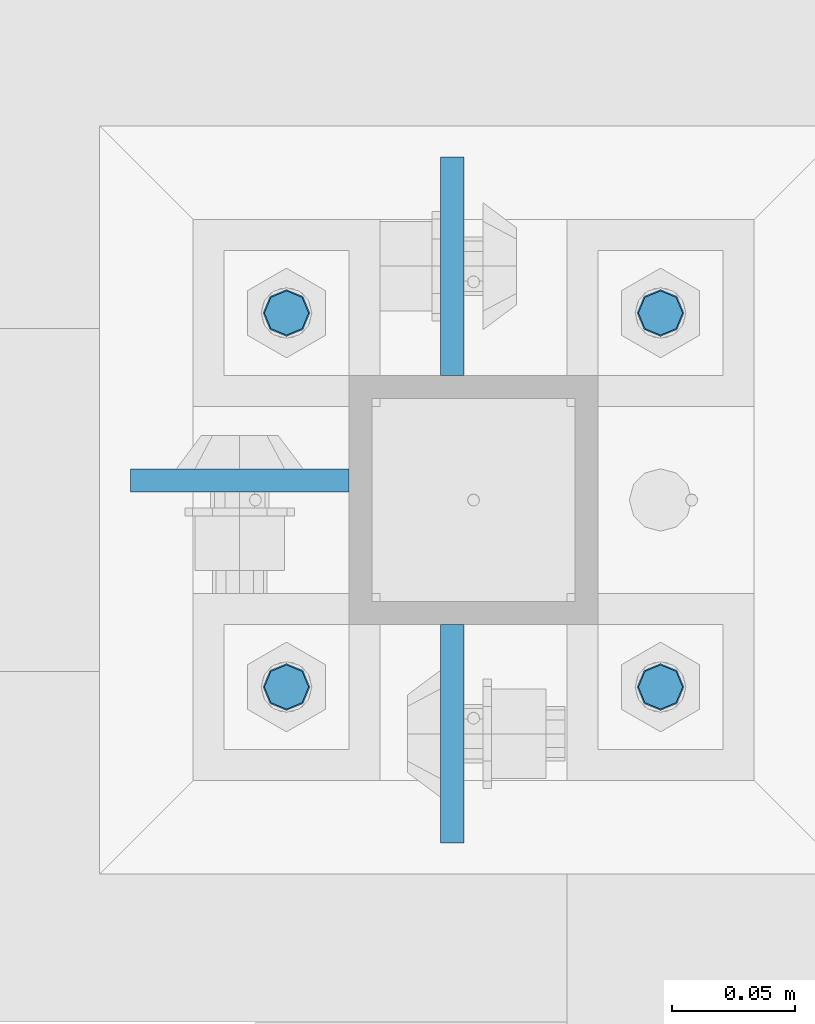
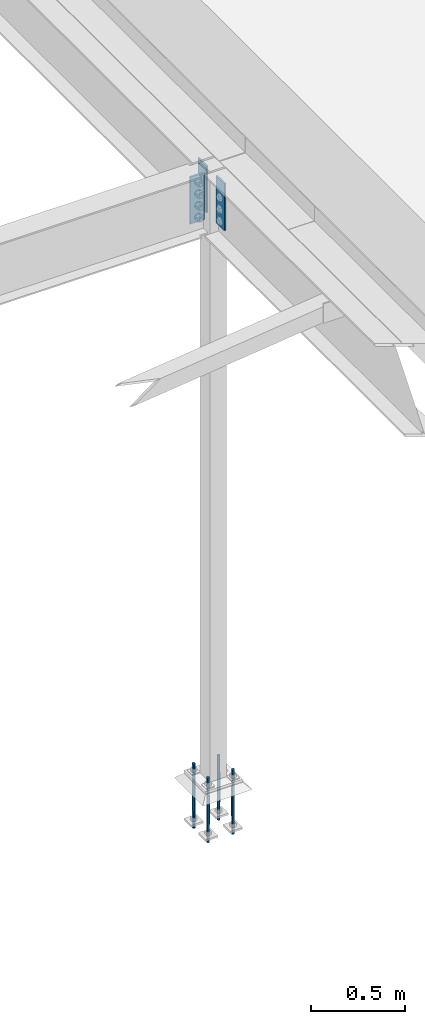
# One storey, part 1550 of 3843: 7 columns, 2 elements without a shape of their own.
"""IFC2X3 building model written with IfcOpenShell, lengths in millimetres."""

import ifcopenshell
import ifcopenshell.guid

model = None  # the IFC model being written
_history = None  # IfcOwnerHistory: only IFC2X3 demands one
_inside = {}  # id of a spatial element -> (the spatial element, [elements in it])
_under = {}  # id of a project, library or spatial element -> (it, [spatial elements below it])
_declared = {}  # id of a project -> (the project, [libraries it declares])
_typed = {}  # id of a type object -> (the type object, [elements of that type])
_made_of = {}  # id of a material, layer set ... -> (it, [elements and type objects made of it])


def new_model(schema):
    """Start an empty IFC model of exactly this schema.

    Asked for "IFC4X3", IfcOpenShell would pick the latest addendum, in which some entities
    have other attributes; the version numbers below select the first issue.
    IFC2X3 requires an IfcOwnerHistory on every rooted entity: one is made here for all.
    """
    global model, _history
    if schema == "IFC4X3":
        model = ifcopenshell.file(schema_version=(4, 3, 0, 0))
    else:
        model = ifcopenshell.file(schema=schema)
    _inside.clear()
    _under.clear()
    _declared.clear()
    _typed.clear()
    _made_of.clear()
    _history = None
    if model.schema == "IFC2X3":
        org = make("IfcOrganization", Name="unknown")
        user = make(
            "IfcPersonAndOrganization",
            ThePerson=make("IfcPerson", FamilyName="unknown"),
            TheOrganization=org,
        )
        app = make(
            "IfcApplication",
            ApplicationDeveloper=org,
            Version="unknown",
            ApplicationFullName="unknown",
            ApplicationIdentifier="unknown",
        )
        _history = make(
            "IfcOwnerHistory",
            OwningUser=user,
            OwningApplication=app,
            ChangeAction="ADDED",
            CreationDate=0,
        )
    return model


def make(cls, **values):
    """One entity of the class cls with the attributes given. An attribute that is None is left unset."""
    return model.create_entity(
        cls, **{name: value for name, value in values.items() if value is not None}
    )


def rooted(cls, **values):
    """An entity with a GlobalId (a new one), such as an element, a storey or a relation."""
    return make(cls, GlobalId=ifcopenshell.guid.new(), OwnerHistory=_history, **values)


def si_unit(unit_type, name, prefix=None):
    """IfcSIUnit, for example si_unit("LENGTHUNIT", "METRE", prefix="MILLI")."""
    return make("IfcSIUnit", UnitType=unit_type, Prefix=prefix, Name=name)


def assignment(units):
    """IfcUnitAssignment: the units of a project."""
    return None if units is None else make("IfcUnitAssignment", Units=units)


def point(xyz):
    """IfcCartesianPoint."""
    return None if xyz is None else make("IfcCartesianPoint", Coordinates=xyz)


def direction(xyz):
    """IfcDirection."""
    return None if xyz is None else make("IfcDirection", DirectionRatios=xyz)


def frame(location, z_axis=None, x_axis=None):
    """IfcAxis2Placement3D, a coordinate frame: its origin and axes. An axis left out is left unset."""
    return make(
        "IfcAxis2Placement3D",
        Location=point(location),
        Axis=direction(z_axis),
        RefDirection=direction(x_axis),
    )


def origin_with_axes():
    """The frame at (0, 0, 0) with the z axis (0, 0, 1) and the x axis (1, 0, 0) written out."""
    return frame((0.0, 0.0, 0.0), z_axis=(0.0, 0.0, 1.0), x_axis=(1.0, 0.0, 0.0))


def place(relative_to, where):
    """IfcLocalPlacement: puts the frame where relative to a parent placement (None: the world)."""
    return make(
        "IfcLocalPlacement", PlacementRelTo=relative_to, RelativePlacement=where
    )


def context(
    kind, dimensions, precision=None, world=None, true_north=None, identifier=None
):
    """IfcGeometricRepresentationContext, for example the 3D "Model" context."""
    return make(
        "IfcGeometricRepresentationContext",
        ContextIdentifier=identifier,
        ContextType=kind,
        CoordinateSpaceDimension=dimensions,
        Precision=precision,
        WorldCoordinateSystem=world,
        TrueNorth=true_north,
    )


def subcontext(parent, identifier, kind, view, scale=None):
    """IfcGeometricRepresentationSubContext, for example "Body" below "Model"."""
    return make(
        "IfcGeometricRepresentationSubContext",
        ContextIdentifier=identifier,
        ContextType=kind,
        ParentContext=parent,
        TargetScale=scale,
        TargetView=view,
    )


def project(units=None, contexts=None):
    """IfcProject with its units and contexts."""
    return rooted(
        "IfcProject",
        Name="project",
        RepresentationContexts=contexts,
        UnitsInContext=assignment(units),
    )


def spatial(cls, under=None, at=None, **own):
    """A site, building, storey or space (cls), placed at a placement, below another one or the project."""
    s = rooted(cls, ObjectPlacement=at, **own)
    if under is not None:
        _under.setdefault(under.id(), (under, []))[1].append(s)
    return s


def faces_of(points, faces, orient=None, outer=None):
    """IfcFace entities. A face is a list of loops; a loop is a list of indices into points, from 0.

    orient and outer hold one flag for each loop. By default every Orientation is true, the
    first loop of a face is its IfcFaceOuterBound and the others are IfcFaceBound.
    """
    made = []
    for i, loops in enumerate(faces):
        bounds = []
        for j, loop in enumerate(loops):
            is_outer = j == 0 if outer is None else outer[i][j]
            bounds.append(
                make(
                    "IfcFaceOuterBound" if is_outer else "IfcFaceBound",
                    Bound=make("IfcPolyLoop", Polygon=[points[k] for k in loop]),
                    Orientation=True if orient is None else orient[i][j],
                )
            )
        made.append(make("IfcFace", Bounds=bounds))
    return made


def faceted_brep(points, faces, orient=None, outer=None, voids=None):
    """IfcFacetedBrep: a solid bounded by flat faces; with voids (closed shells), ...WithVoids."""
    shared = [point(p) for p in points]
    hull = make("IfcClosedShell", CfsFaces=faces_of(shared, faces, orient, outer))
    if voids is None:
        return make("IfcFacetedBrep", Outer=hull)
    return make(
        "IfcFacetedBrepWithVoids",
        Outer=hull,
        Voids=[
            make(cls, CfsFaces=faces_of(shared, fs, o, b)) for cls, fs, o, b in voids
        ],
    )


def shape(context_of_items, identifier, shape_type, items):
    """IfcShapeRepresentation: the items that make up one representation, for example the "Body"."""
    return make(
        "IfcShapeRepresentation",
        ContextOfItems=context_of_items,
        RepresentationIdentifier=identifier,
        RepresentationType=shape_type,
        Items=items,
    )


def material(Name=None, Category=None):
    """IfcMaterial."""
    return make("IfcMaterial", Name=Name, Category=Category)


def made_of(thing, what):
    """Note that an element or type object is made of a material, layer set ...; save() writes the relation."""
    if what is not None:
        _made_of.setdefault(what.id(), (what, []))[1].append(thing)
    return thing


def type_object(cls, material=None, **own):
    """A type object (cls), such as IfcWallType, which elements share."""
    return made_of(rooted(cls, **own), material)


def element(
    cls,
    number,
    at=None,
    inside=None,
    cuts=None,
    type_object=None,
    material=None,
    context=None,
    identifier="Body",
    shape_type=None,
    held_by="IfcProductDefinitionShape",
    body=None,
    shapes=None,
    **own,
):
    """One element of the class cls, such as IfcWall. Its Tag is "e" and its number.

    at: its placement. inside: the storey or other place that contains it. cuts: it is an
    opening in that element (IfcRelVoidsElement). A single representation is given by context,
    identifier, shape_type and body (its items); several are given by shapes. held_by: the class
    of the entity that holds the representations. save() writes the other relations.
    """
    e = rooted(cls, Tag="e%d" % number, ObjectPlacement=at, **own)
    if body is not None:
        shapes = [shape(context, identifier, shape_type, body)]
    if shapes is not None:
        e.Representation = make(held_by, Representations=shapes)
    if inside is not None:
        _inside.setdefault(inside.id(), (inside, []))[1].append(e)
    if cuts is not None:
        rooted(
            "IfcRelVoidsElement", RelatingBuildingElement=cuts, RelatedOpeningElement=e
        )
    if type_object is not None:
        _typed.setdefault(type_object.id(), (type_object, []))[1].append(e)
    return made_of(e, material)


def aggregate(whole, parts):
    """IfcRelAggregates: a whole, such as a stair, and the parts it consists of."""
    return rooted("IfcRelAggregates", RelatingObject=whole, RelatedObjects=parts)


def save(model, path):
    """Write the relations noted so far, then the file.

    IfcRelAggregates (storeys below a building ...), IfcRelContainedInSpatialStructure (elements
    in a storey), IfcRelDefinesByType, IfcRelAssociatesMaterial and IfcRelDeclares: one each for
    every whole, place, type object, material and project.
    """
    for whole, parts in _under.values():
        aggregate(whole, parts)
    for where, things in _inside.values():
        rooted(
            "IfcRelContainedInSpatialStructure",
            RelatedElements=things,
            RelatingStructure=where,
        )
    for kind, things in _typed.values():
        rooted("IfcRelDefinesByType", RelatedObjects=things, RelatingType=kind)
    for what, things in _made_of.values():
        rooted("IfcRelAssociatesMaterial", RelatedObjects=things, RelatingMaterial=what)
    for by, libraries in _declared.values():
        rooted("IfcRelDeclares", RelatingContext=by, RelatedDefinitions=libraries)
    model.write(path)


model = new_model("IFC2X3")

# Units and contexts
model_context = context("Model", 3, precision=1e-05, world=origin_with_axes())
body_context = subcontext(model_context, "Body", "Model", "MODEL_VIEW")
ifc_project = project(units=[si_unit("LENGTHUNIT", "METRE", prefix="MILLI"), si_unit("AREAUNIT", "SQUARE_METRE"), si_unit("VOLUMEUNIT", "CUBIC_METRE"), si_unit("MASSUNIT", "GRAM", prefix="KILO"), si_unit("TIMEUNIT", "SECOND"), si_unit("PLANEANGLEUNIT", "RADIAN"), si_unit("SOLIDANGLEUNIT", "STERADIAN"), si_unit("THERMODYNAMICTEMPERATUREUNIT", "DEGREE_CELSIUS"), si_unit("LUMINOUSINTENSITYUNIT", "LUMEN")], contexts=[model_context])

# Site, building, storey
site_placement = place(None, origin_with_axes())
site = spatial("IfcSite", under=ifc_project, at=site_placement, CompositionType="ELEMENT")
building_placement = place(site_placement, origin_with_axes())
building = spatial("IfcBuilding", under=site, at=building_placement, Name="Undefined", CompositionType="ELEMENT")
storey_placement = place(building_placement, origin_with_axes())
storey = spatial("IfcBuildingStorey", under=building, at=storey_placement, Name="Undefined", CompositionType="ELEMENT", Elevation=0.0)

# Assembly, columns
assembly_1_placement = place(storey_placement, origin_with_axes())
assembly_1 = element("IfcElementAssembly", 1, at=assembly_1_placement, inside=storey, Name="COLUMN", AssemblyPlace="NOTDEFINED", PredefinedType="RIGID_FRAME")
ifc_material_1 = material(Name="STEEL/A572-50")
column_type_1 = type_object("IfcColumnType", PredefinedType="NOTDEFINED")
column_1_placement = place(assembly_1_placement, frame((38811.9945000649, 67176.65, 33693.0999993376), z_axis=(0.0, 1.0, 0.0), x_axis=(0.0, 0.0, 1.0)))
column_1 = element("IfcColumn", 2, at=column_1_placement, type_object=column_type_1, material=ifc_material_1, Name="PLATE", context=body_context, shape_type="Brep", body=[
    faceted_brep([(0.0, 4.76249999999709, -44.4500000000007), (0.0, 4.76249999999709, 44.4500000000007), (304.799999999996, 4.76249999999709, 44.4500000000007), (304.799999999996, 4.76249999999709, -44.4500000000007), (0.0, -4.76249999999709, 44.4500000000007), (304.799999999996, -4.76249999999709, 44.4500000000007), (0.0, -4.76249999999709, -44.4500000000007), (304.799999999996, -4.76249999999709, -44.4500000000007)], [[[0, 1, 2, 3]], [[1, 4, 5, 2]], [[4, 6, 7, 5]], [[6, 0, 3, 7]], [[5, 7, 3, 2]], [[6, 4, 1, 0]]]),
])
column_2_placement = place(assembly_1_placement, frame((38811.9945000649, 67367.15, 33693.0999993376), z_axis=(0.0, -1.0, 0.0), x_axis=(0.0, 0.0, 1.0)))
column_2 = element("IfcColumn", 3, at=column_2_placement, type_object=column_type_1, material=ifc_material_1, Name="PLATE", context=body_context, shape_type="Brep", body=[
    faceted_brep([(0.0, 4.76249999999709, -44.4500000000007), (0.0, 4.76249999999709, 44.4500000000007), (304.799999999996, 4.76249999999709, 44.4500000000007), (304.799999999996, 4.76249999999709, -44.4500000000007), (0.0, -4.76249999999709, 44.4500000000007), (304.799999999996, -4.76249999999709, 44.4500000000007), (0.0, -4.76249999999709, -44.4500000000007), (304.799999999996, -4.76249999999709, -44.4500000000007)], [[[0, 1, 2, 3]], [[1, 4, 5, 2]], [[4, 6, 7, 5]], [[6, 0, 3, 7]], [[5, 7, 3, 2]], [[6, 4, 1, 0]]]),
])
column_3_placement = place(assembly_1_placement, frame((38725.475, 67279.8374999523, 33693.1), z_axis=(1.0, 0.0, 0.0), x_axis=(0.0, 0.0, 1.0)))
column_3 = element("IfcColumn", 4, at=column_3_placement, type_object=column_type_1, material=ifc_material_1, Name="PLATE", context=body_context, shape_type="Brep", body=[
    faceted_brep([(0.0, 4.76249999999709, -44.4500000000007), (0.0, 4.76249999999709, 44.4500000000007), (304.799999999996, 4.76249999999709, 44.4500000000007), (304.799999999996, 4.76249999999709, -44.4500000000007), (0.0, -4.76249999999709, 44.4500000000007), (304.799999999996, -4.76249999999709, 44.4500000000007), (0.0, -4.76249999999709, -44.4500000000007), (304.799999999996, -4.76249999999709, -44.4500000000007)], [[[0, 1, 2, 3]], [[1, 4, 5, 2]], [[4, 6, 7, 5]], [[6, 0, 3, 7]], [[5, 7, 3, 2]], [[6, 4, 1, 0]]]),
])
aggregate(assembly_1, [column_1, column_2, column_3])

assembly_2_placement = place(storey_placement, origin_with_axes())
assembly_2 = element("IfcElementAssembly", 5, at=assembly_2_placement, inside=storey, Name="TEMPLATE", AssemblyPlace="NOTDEFINED", PredefinedType="RIGID_FRAME")
ifc_material_2 = material(Name="Undefined/F1554-GR.55")
column_type_2 = type_object("IfcColumnType", PredefinedType="NOTDEFINED")
column_4_placement = place(assembly_2_placement, frame((38896.925, 67195.7, 30022.8), z_axis=(1.0, 0.0, 0.0), x_axis=(0.0, 0.0, -1.0)))
column_4 = element("IfcColumn", 6, at=column_4_placement, type_object=column_type_2, material=ifc_material_2, Name="ANCHOR_ROD", context=body_context, shape_type="Brep", body=[
    faceted_brep([(-114.300000000003, -6.36396103068546, 6.36396103067818), (-114.300000000003, 0.0, 9.0), (-114.300000000003, 6.36396103068546, 6.36396103067818), (-114.300000000003, 9.0, 0.0), (-114.300000000003, 6.36396103068546, -6.36396103067818), (-114.300000000003, 0.0, -9.0), (-114.300000000003, -6.36396103068546, -6.36396103067818), (-114.300000000003, -9.0, 0.0), (0.0, 6.36396103068546, -6.36396103067818), (0.0, 0.0, -9.0), (0.0, -6.36396103068546, -6.36396103067818), (0.0, -9.0, 0.0), (0.0, -6.36396103068546, 6.36396103067818), (0.0, 0.0, 9.0), (0.0, 6.36396103068546, 6.36396103067818), (0.0, 9.0, 0.0), (0.0, -6.73519209080405, 6.73519209079677), (-9.87109982941227e-13, 2.91322521661641e-12, 9.52499961853027), (0.0, 6.73519209080405, 6.73519209079677), (0.0, 9.52500000000146, 0.0), (0.0, 6.73519209080405, -6.73519209079677), (2.95075507493764e-12, 2.91322521661641e-12, -9.52499961853027), (0.0, -6.73519209080405, -6.73519209079677), (0.0, -9.52500000000146, 0.0), (190.5, -9.52499999999418, 0.0), (190.5, -6.73519209079677, 6.73519209080405), (190.5, 0.0, 9.52500000000146), (190.5, 6.73519209079677, 6.73519209080405), (190.5, 9.52499999999418, 0.0), (190.5, 6.73519209079677, -6.73519209080405), (190.5, 0.0, -9.52500000000146), (190.5, -6.73519209079677, -6.73519209080405), (190.5, -6.36396103068546, 6.36396103067818), (190.5, 0.0, 9.0), (190.5, 6.36396103068546, 6.36396103067818), (190.5, 9.0, 0.0), (190.5, 6.36396103068546, -6.36396103067818), (190.5, 0.0, -9.0), (190.5, -6.36396103068546, -6.36396103067818), (190.5, -9.0, 0.0), (304.799999999999, 0.0, -9.0), (304.799999999999, 6.36396103068546, -6.36396103067818), (304.799999999999, 9.0, 0.0), (304.799999999999, 6.36396103068546, 6.36396103067818), (304.799999999999, 0.0, 9.0), (304.799999999999, -6.36396103068546, 6.36396103067818), (304.799999999999, -9.0, 0.0), (304.799999999999, -6.36396103068546, -6.36396103067818)], [[[0, 1, 2, 3, 4, 5, 6, 7]], [[5, 4, 8, 9]], [[6, 5, 9, 10]], [[7, 6, 10, 11]], [[0, 7, 11, 12]], [[1, 0, 12, 13]], [[2, 1, 13, 14]], [[3, 2, 14, 15]], [[4, 3, 15, 8]], [[16, 17, 18, 19, 20, 21, 22, 23], [14, 13, 12, 11, 10, 9, 8, 15]], [[16, 23, 24, 25]], [[17, 16, 25, 26]], [[18, 17, 26, 27]], [[19, 18, 27, 28]], [[20, 19, 28, 29]], [[21, 20, 29, 30]], [[22, 21, 30, 31]], [[23, 22, 31, 24]], [[30, 29, 28, 27, 26, 25, 24, 31], [32, 33, 34, 35, 36, 37, 38, 39]], [[40, 41, 42, 43, 44, 45, 46, 47]], [[45, 44, 33, 32]], [[46, 45, 32, 39]], [[47, 46, 39, 38]], [[40, 47, 38, 37]], [[41, 40, 37, 36]], [[42, 41, 36, 35]], [[43, 42, 35, 34]], [[44, 43, 34, 33]]]),
])
column_5_placement = place(assembly_2_placement, frame((38896.925, 67348.1, 30022.8), z_axis=(-1.0, 0.0, 0.0), x_axis=(0.0, 0.0, -1.0)))
column_5 = element("IfcColumn", 7, at=column_5_placement, type_object=column_type_2, material=ifc_material_2, Name="ANCHOR_ROD", context=body_context, shape_type="Brep", body=[
    faceted_brep([(-114.300000000003, -6.36396103068546, 6.36396103067818), (-114.300000000003, 0.0, 9.0), (-114.300000000003, 6.36396103068546, 6.36396103067818), (-114.300000000003, 9.0, 0.0), (-114.300000000003, 6.36396103068546, -6.36396103067818), (-114.300000000003, 0.0, -9.0), (-114.300000000003, -6.36396103068546, -6.36396103067818), (-114.300000000003, -9.0, 0.0), (0.0, 6.36396103068546, -6.36396103067818), (0.0, 0.0, -9.0), (0.0, -6.36396103068546, -6.36396103067818), (0.0, -9.0, 0.0), (0.0, -6.36396103068546, 6.36396103067818), (0.0, 0.0, 9.0), (0.0, 6.36396103068546, 6.36396103067818), (0.0, 9.0, 0.0), (0.0, -6.73519209080405, 6.73519209079677), (-9.87109982941227e-13, 2.91322521661641e-12, 9.52499961853027), (0.0, 6.73519209080405, 6.73519209079677), (0.0, 9.52500000000146, 0.0), (0.0, 6.73519209080405, -6.73519209079677), (2.95075507493764e-12, 2.91322521661641e-12, -9.52499961853027), (0.0, -6.73519209080405, -6.73519209079677), (0.0, -9.52500000000146, 0.0), (190.5, -9.52499999999418, 0.0), (190.5, -6.73519209079677, 6.73519209080405), (190.5, 0.0, 9.52500000000146), (190.5, 6.73519209079677, 6.73519209080405), (190.5, 9.52499999999418, 0.0), (190.5, 6.73519209079677, -6.73519209080405), (190.5, 0.0, -9.52500000000146), (190.5, -6.73519209079677, -6.73519209080405), (190.5, -6.36396103068546, 6.36396103067818), (190.5, 0.0, 9.0), (190.5, 6.36396103068546, 6.36396103067818), (190.5, 9.0, 0.0), (190.5, 6.36396103068546, -6.36396103067818), (190.5, 0.0, -9.0), (190.5, -6.36396103068546, -6.36396103067818), (190.5, -9.0, 0.0), (304.799999999999, 0.0, -9.0), (304.799999999999, 6.36396103068546, -6.36396103067818), (304.799999999999, 9.0, 0.0), (304.799999999999, 6.36396103068546, 6.36396103067818), (304.799999999999, 0.0, 9.0), (304.799999999999, -6.36396103068546, 6.36396103067818), (304.799999999999, -9.0, 0.0), (304.799999999999, -6.36396103068546, -6.36396103067818)], [[[0, 1, 2, 3, 4, 5, 6, 7]], [[5, 4, 8, 9]], [[6, 5, 9, 10]], [[7, 6, 10, 11]], [[0, 7, 11, 12]], [[1, 0, 12, 13]], [[2, 1, 13, 14]], [[3, 2, 14, 15]], [[4, 3, 15, 8]], [[16, 17, 18, 19, 20, 21, 22, 23], [14, 13, 12, 11, 10, 9, 8, 15]], [[16, 23, 24, 25]], [[17, 16, 25, 26]], [[18, 17, 26, 27]], [[19, 18, 27, 28]], [[20, 19, 28, 29]], [[21, 20, 29, 30]], [[22, 21, 30, 31]], [[23, 22, 31, 24]], [[30, 29, 28, 27, 26, 25, 24, 31], [32, 33, 34, 35, 36, 37, 38, 39]], [[40, 41, 42, 43, 44, 45, 46, 47]], [[45, 44, 33, 32]], [[46, 45, 32, 39]], [[47, 46, 39, 38]], [[40, 47, 38, 37]], [[41, 40, 37, 36]], [[42, 41, 36, 35]], [[43, 42, 35, 34]], [[44, 43, 34, 33]]]),
])
column_6_placement = place(assembly_2_placement, frame((38744.525, 67195.7, 30022.8), z_axis=(1.0, 0.0, 0.0), x_axis=(0.0, 0.0, -1.0)))
column_6 = element("IfcColumn", 8, at=column_6_placement, type_object=column_type_2, material=ifc_material_2, Name="ANCHOR_ROD", context=body_context, shape_type="Brep", body=[
    faceted_brep([(-114.300000000003, -6.36396103068546, 6.36396103067818), (-114.300000000003, 0.0, 9.0), (-114.300000000003, 6.36396103068546, 6.36396103067818), (-114.300000000003, 9.0, 0.0), (-114.300000000003, 6.36396103068546, -6.36396103067818), (-114.300000000003, 0.0, -9.0), (-114.300000000003, -6.36396103068546, -6.36396103067818), (-114.300000000003, -9.0, 0.0), (0.0, 6.36396103068546, -6.36396103067818), (0.0, 0.0, -9.0), (0.0, -6.36396103068546, -6.36396103067818), (0.0, -9.0, 0.0), (0.0, -6.36396103068546, 6.36396103067818), (0.0, 0.0, 9.0), (0.0, 6.36396103068546, 6.36396103067818), (0.0, 9.0, 0.0), (0.0, -6.73519209080405, 6.73519209079677), (-9.87109982941227e-13, 2.91322521661641e-12, 9.52499961853027), (0.0, 6.73519209080405, 6.73519209079677), (0.0, 9.52500000000146, 0.0), (0.0, 6.73519209080405, -6.73519209079677), (2.95075507493764e-12, 2.91322521661641e-12, -9.52499961853027), (0.0, -6.73519209080405, -6.73519209079677), (0.0, -9.52500000000146, 0.0), (190.5, -9.52499999999418, 0.0), (190.5, -6.73519209079677, 6.73519209080405), (190.5, 0.0, 9.52500000000146), (190.5, 6.73519209079677, 6.73519209080405), (190.5, 9.52499999999418, 0.0), (190.5, 6.73519209079677, -6.73519209080405), (190.5, 0.0, -9.52500000000146), (190.5, -6.73519209079677, -6.73519209080405), (190.5, -6.36396103068546, 6.36396103067818), (190.5, 0.0, 9.0), (190.5, 6.36396103068546, 6.36396103067818), (190.5, 9.0, 0.0), (190.5, 6.36396103068546, -6.36396103067818), (190.5, 0.0, -9.0), (190.5, -6.36396103068546, -6.36396103067818), (190.5, -9.0, 0.0), (304.799999999999, 0.0, -9.0), (304.799999999999, 6.36396103068546, -6.36396103067818), (304.799999999999, 9.0, 0.0), (304.799999999999, 6.36396103068546, 6.36396103067818), (304.799999999999, 0.0, 9.0), (304.799999999999, -6.36396103068546, 6.36396103067818), (304.799999999999, -9.0, 0.0), (304.799999999999, -6.36396103068546, -6.36396103067818)], [[[0, 1, 2, 3, 4, 5, 6, 7]], [[5, 4, 8, 9]], [[6, 5, 9, 10]], [[7, 6, 10, 11]], [[0, 7, 11, 12]], [[1, 0, 12, 13]], [[2, 1, 13, 14]], [[3, 2, 14, 15]], [[4, 3, 15, 8]], [[16, 17, 18, 19, 20, 21, 22, 23], [14, 13, 12, 11, 10, 9, 8, 15]], [[16, 23, 24, 25]], [[17, 16, 25, 26]], [[18, 17, 26, 27]], [[19, 18, 27, 28]], [[20, 19, 28, 29]], [[21, 20, 29, 30]], [[22, 21, 30, 31]], [[23, 22, 31, 24]], [[30, 29, 28, 27, 26, 25, 24, 31], [32, 33, 34, 35, 36, 37, 38, 39]], [[40, 41, 42, 43, 44, 45, 46, 47]], [[45, 44, 33, 32]], [[46, 45, 32, 39]], [[47, 46, 39, 38]], [[40, 47, 38, 37]], [[41, 40, 37, 36]], [[42, 41, 36, 35]], [[43, 42, 35, 34]], [[44, 43, 34, 33]]]),
])
column_7_placement = place(assembly_2_placement, frame((38744.525, 67348.1, 30022.8), z_axis=(-1.0, 0.0, 0.0), x_axis=(0.0, 0.0, -1.0)))
column_7 = element("IfcColumn", 9, at=column_7_placement, type_object=column_type_2, material=ifc_material_2, Name="ANCHOR_ROD", context=body_context, shape_type="Brep", body=[
    faceted_brep([(-114.300000000003, -6.36396103068546, 6.36396103067818), (-114.300000000003, 0.0, 9.0), (-114.300000000003, 6.36396103068546, 6.36396103067818), (-114.300000000003, 9.0, 0.0), (-114.300000000003, 6.36396103068546, -6.36396103067818), (-114.300000000003, 0.0, -9.0), (-114.300000000003, -6.36396103068546, -6.36396103067818), (-114.300000000003, -9.0, 0.0), (0.0, 6.36396103068546, -6.36396103067818), (0.0, 0.0, -9.0), (0.0, -6.36396103068546, -6.36396103067818), (0.0, -9.0, 0.0), (0.0, -6.36396103068546, 6.36396103067818), (0.0, 0.0, 9.0), (0.0, 6.36396103068546, 6.36396103067818), (0.0, 9.0, 0.0), (0.0, -6.73519209080405, 6.73519209079677), (-9.87109982941227e-13, 2.91322521661641e-12, 9.52499961853027), (0.0, 6.73519209080405, 6.73519209079677), (0.0, 9.52500000000146, 0.0), (0.0, 6.73519209080405, -6.73519209079677), (2.95075507493764e-12, 2.91322521661641e-12, -9.52499961853027), (0.0, -6.73519209080405, -6.73519209079677), (0.0, -9.52500000000146, 0.0), (190.5, -9.52499999999418, 0.0), (190.5, -6.73519209079677, 6.73519209080405), (190.5, 0.0, 9.52500000000146), (190.5, 6.73519209079677, 6.73519209080405), (190.5, 9.52499999999418, 0.0), (190.5, 6.73519209079677, -6.73519209080405), (190.5, 0.0, -9.52500000000146), (190.5, -6.73519209079677, -6.73519209080405), (190.5, -6.36396103068546, 6.36396103067818), (190.5, 0.0, 9.0), (190.5, 6.36396103068546, 6.36396103067818), (190.5, 9.0, 0.0), (190.5, 6.36396103068546, -6.36396103067818), (190.5, 0.0, -9.0), (190.5, -6.36396103068546, -6.36396103067818), (190.5, -9.0, 0.0), (304.799999999999, 0.0, -9.0), (304.799999999999, 6.36396103068546, -6.36396103067818), (304.799999999999, 9.0, 0.0), (304.799999999999, 6.36396103068546, 6.36396103067818), (304.799999999999, 0.0, 9.0), (304.799999999999, -6.36396103068546, 6.36396103067818), (304.799999999999, -9.0, 0.0), (304.799999999999, -6.36396103068546, -6.36396103067818)], [[[0, 1, 2, 3, 4, 5, 6, 7]], [[5, 4, 8, 9]], [[6, 5, 9, 10]], [[7, 6, 10, 11]], [[0, 7, 11, 12]], [[1, 0, 12, 13]], [[2, 1, 13, 14]], [[3, 2, 14, 15]], [[4, 3, 15, 8]], [[16, 17, 18, 19, 20, 21, 22, 23], [14, 13, 12, 11, 10, 9, 8, 15]], [[16, 23, 24, 25]], [[17, 16, 25, 26]], [[18, 17, 26, 27]], [[19, 18, 27, 28]], [[20, 19, 28, 29]], [[21, 20, 29, 30]], [[22, 21, 30, 31]], [[23, 22, 31, 24]], [[30, 29, 28, 27, 26, 25, 24, 31], [32, 33, 34, 35, 36, 37, 38, 39]], [[40, 41, 42, 43, 44, 45, 46, 47]], [[45, 44, 33, 32]], [[46, 45, 32, 39]], [[47, 46, 39, 38]], [[40, 47, 38, 37]], [[41, 40, 37, 36]], [[42, 41, 36, 35]], [[43, 42, 35, 34]], [[44, 43, 34, 33]]]),
])
aggregate(assembly_2, [column_4, column_5, column_6, column_7])

save(model, "model.ifc")
